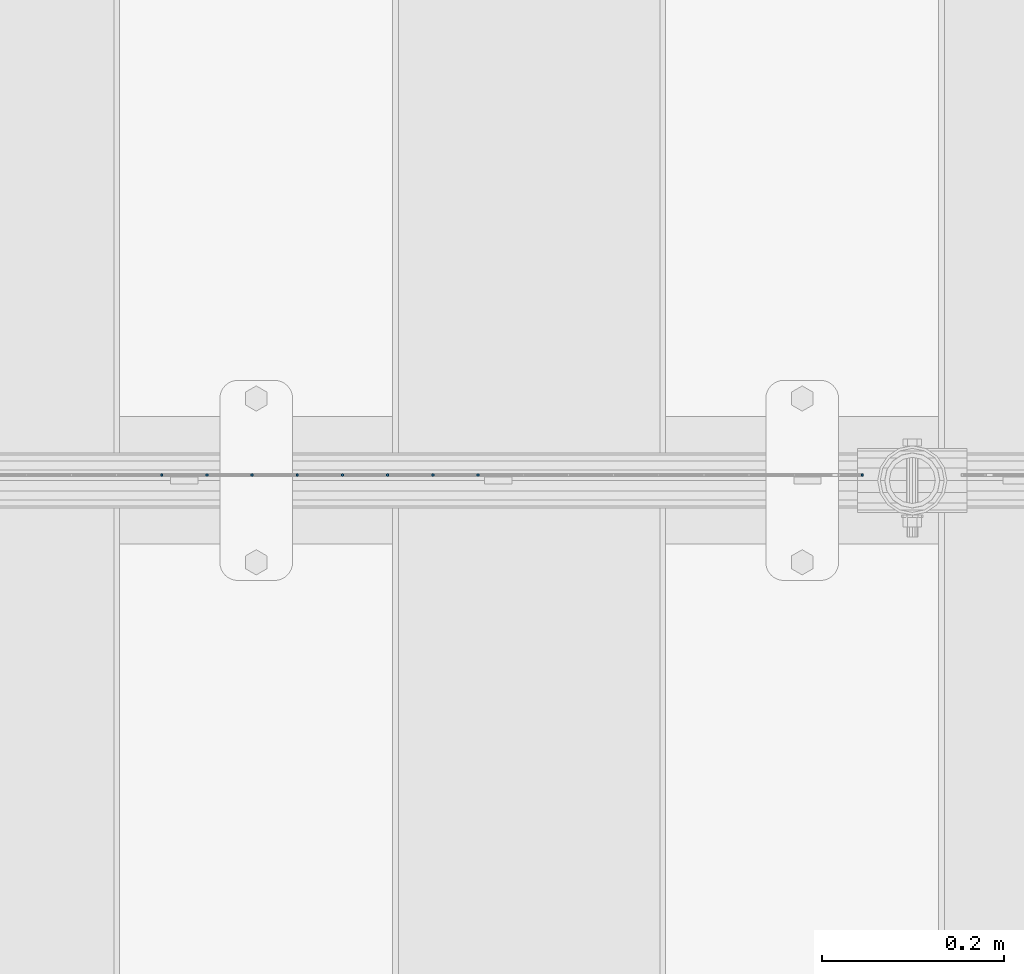
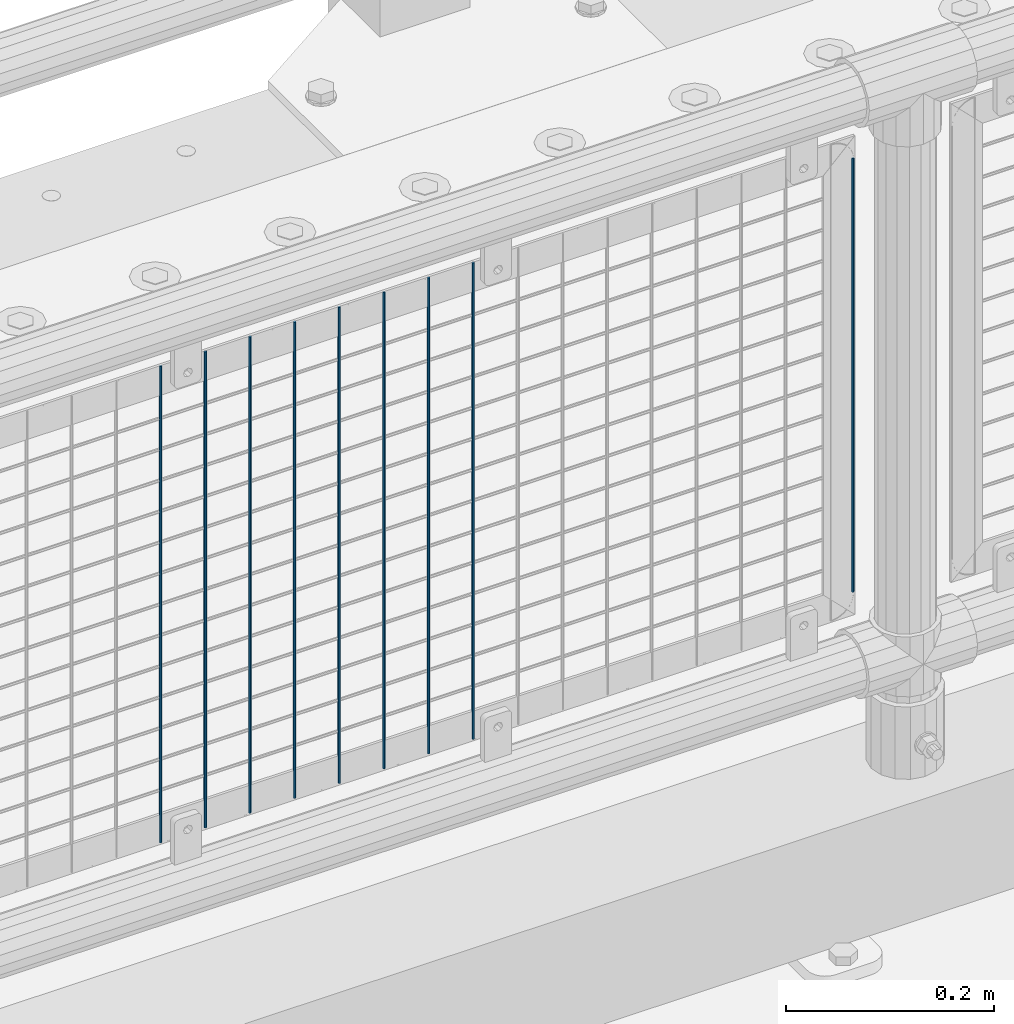
# One storey, part 75 of 247: 9 columns.
"""IFC2X3 building model written with IfcOpenShell, lengths in millimetres."""

from ifc_helpers import new_model, si_unit, frame, origin_with_axes, place, context, subcontext, project, spatial, faceted_brep, material, type_object, element, save


model = new_model("IFC2X3")

# Units and contexts
model_context = context("Model", 3, precision=1e-05, world=origin_with_axes())
body_context = subcontext(model_context, "Body", "Model", "MODEL_VIEW")
ifc_project = project(units=[si_unit("LENGTHUNIT", "METRE", prefix="MILLI"), si_unit("AREAUNIT", "SQUARE_METRE"), si_unit("VOLUMEUNIT", "CUBIC_METRE"), si_unit("MASSUNIT", "GRAM", prefix="KILO"), si_unit("TIMEUNIT", "SECOND"), si_unit("PLANEANGLEUNIT", "RADIAN"), si_unit("SOLIDANGLEUNIT", "STERADIAN"), si_unit("THERMODYNAMICTEMPERATUREUNIT", "DEGREE_CELSIUS"), si_unit("LUMINOUSINTENSITYUNIT", "LUMEN")], contexts=[model_context])

# Site, building, storey
site_placement = place(None, origin_with_axes())
site = spatial("IfcSite", under=ifc_project, at=site_placement, CompositionType="ELEMENT")
building_placement = place(site_placement, origin_with_axes())
building = spatial("IfcBuilding", under=site, at=building_placement, Name="Standard", CompositionType="ELEMENT")
storey_placement = place(building_placement, origin_with_axes())
storey = spatial("IfcBuildingStorey", under=building, at=storey_placement, Name="Undefined", CompositionType="ELEMENT", Elevation=0.0)

# Columns
ifc_material = material(Name="Misc_Undefined")
column_type = type_object("IfcColumnType", Name="D3", PredefinedType="NOTDEFINED")
for number, where, z_axis, x_axis in (
    (1, (3343.755, 7670.5, 353.02), (-1.0, 0.0, 0.0), (0.0, 0.0, 1.0)),
    (2, (3294.1, 7670.5, 353.02), (-1.0, 0.0, 0.0), (0.0, 0.0, 1.0)),
    (3, (3244.445, 7670.5, 353.02), (-1.0, 0.0, 0.0), (0.0, 0.0, 1.0)),
    (4, (3194.79, 7670.5, 353.02), (-1.0, 0.0, 0.0), (0.0, 0.0, 1.0)),
    (5, (3145.135, 7670.5, 353.02), (-1.0, 0.0, 0.0), (0.0, 0.0, 1.0)),
    (6, (3095.48, 7670.5, 353.02), (-1.0, 0.0, 0.0), (0.0, 0.0, 1.0)),
    (7, (3045.825, 7670.5, 353.02), (-1.0, 0.0, 0.0), (0.0, 0.0, 1.0)),
    (8, (2996.17, 7670.5, 353.02), (-1.0, 0.0, 0.0), (0.0, 0.0, 1.0)),
):
    element("IfcColumn", number, at=place(storey_placement, frame(where, z_axis=z_axis, x_axis=x_axis)), inside=storey, type_object=column_type, material=ifc_material, ObjectType="D3", context=body_context, shape_type="Brep", body=[
        faceted_brep([(1.81898940354586e-12, -1.5, -5.6843418860808e-14), (0.0, -0.75, -1.29903810567703), (560.0, -0.75, -1.29903810567703), (560.0, -1.5, 0.0), (0.0, 0.75, -1.29903810567703), (560.0, 0.75, -1.29903810567703), (1.81898940354586e-12, 1.5, -5.6843418860808e-14), (560.0, 1.5, 0.0), (0.0, 0.75, 1.29903810567703), (560.0, 0.75, 1.29903810567703), (0.0, -0.75, 1.29903810567703), (560.0, -0.75, 1.29903810567703)], [[[0, 1, 2, 3]], [[1, 4, 5, 2]], [[4, 6, 7, 5]], [[6, 8, 9, 7]], [[8, 10, 11, 9]], [[10, 0, 3, 11]], [[5, 7, 9, 11, 3, 2]], [[10, 8, 6, 4, 1, 0]]]),
    ])
column_placement = place(storey_placement, frame((3766.0, 7670.5, 378.02), z_axis=(-1.0, 0.0, 0.0), x_axis=(0.0, 0.0, 1.0)))
element("IfcColumn", 9, at=column_placement, inside=storey, type_object=column_type, material=ifc_material, ObjectType="D3", context=body_context, shape_type="Brep", body=[
    faceted_brep([(1.81898940354586e-12, -1.5, -5.6843418860808e-14), (0.0, -0.75, -1.29903810567703), (510.0, -0.75, -1.29903810567703), (510.0, -1.5, 0.0), (0.0, 0.75, -1.29903810567703), (510.0, 0.75, -1.29903810567703), (1.81898940354586e-12, 1.5, -5.6843418860808e-14), (510.0, 1.5, 0.0), (0.0, 0.75, 1.29903810567703), (510.0, 0.75, 1.29903810567703), (0.0, -0.75, 1.29903810567703), (510.0, -0.75, 1.29903810567703)], [[[0, 1, 2, 3]], [[1, 4, 5, 2]], [[4, 6, 7, 5]], [[6, 8, 9, 7]], [[8, 10, 11, 9]], [[10, 0, 3, 11]], [[5, 7, 9, 11, 3, 2]], [[10, 8, 6, 4, 1, 0]]]),
])

save(model, "model.ifc")
